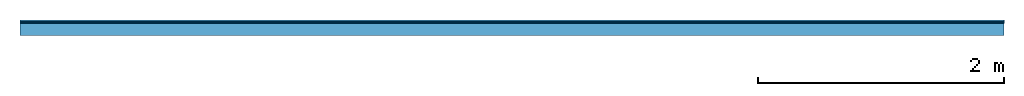
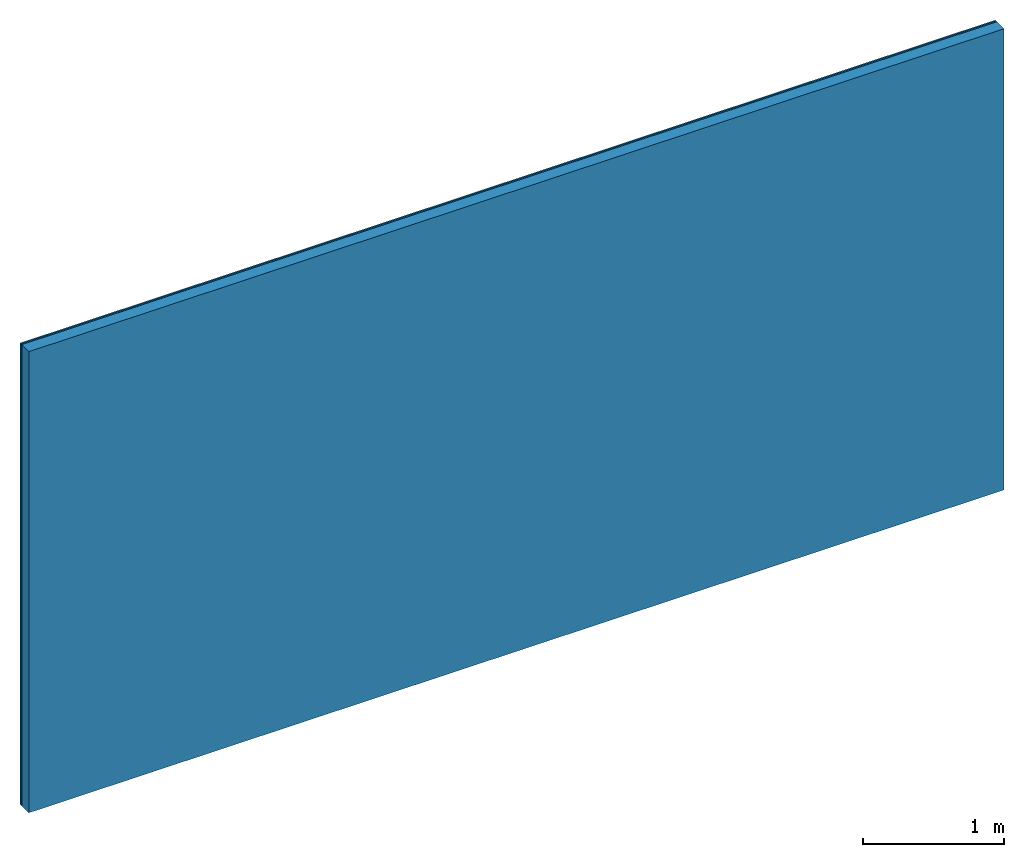
# One storey: 2 plates, 1 member, 1 element without a shape of its own.
"""IFC4 building model written with IfcOpenShell, lengths in metres."""

from ifc_helpers import new_model, si_unit, derived_unit, direction, frame, frame_2d, origin, origin_with_axes, place, context, project, spatial, rectangle, extrude, material, layer, layer_set, type_object, element, aggregate, save


model = new_model("IFC4")

# Units and contexts
plan_context = context("Plan", 3, precision=1e-05, world=origin(), true_north=direction((0.0, 1.0)))
model_context = context("Model", 3, precision=1e-05, world=origin(), true_north=direction((0.0, 1.0)))
ifc_project = project(units=[si_unit("LENGTHUNIT", "METRE"), derived_unit("SOUNDPRESSUREUNIT", [(si_unit("PRESSUREUNIT", "PASCAL", prefix="MICRO"), 0)]), si_unit("ENERGYUNIT", "JOULE", prefix="MEGA"), si_unit("MASSUNIT", "GRAM", prefix="KILO"), derived_unit("THERMALTRANSMITTANCEUNIT", [(si_unit("POWERUNIT", "WATT"), 1), (si_unit("AREAUNIT", "SQUARE_METRE"), -1), (si_unit("THERMODYNAMICTEMPERATUREUNIT", "KELVIN"), -1)]), derived_unit("AREADENSITYUNIT", [(si_unit("MASSUNIT", "GRAM", prefix="KILO"), 1), (si_unit("AREAUNIT", "SQUARE_METRE"), -1)]), derived_unit("USERDEFINED", [(si_unit("ENERGYUNIT", "JOULE", prefix="MEGA"), 1), (si_unit("AREAUNIT", "SQUARE_METRE"), -1)])], contexts=[plan_context, model_context])

# Site, building, storey
site = spatial("IfcSite", under=ifc_project)
building_placement = place(None, origin())
building = spatial("IfcBuilding", under=site, at=building_placement)
storey_placement = place(building_placement, origin())
storey = spatial("IfcBuildingStorey", under=building, at=storey_placement)

# Wall, member, plates
ifc_material_1 = material(Name="joints", Category="04.017")
ifc_layer_1 = layer(ifc_material_1, 0.0, Name="Surface")
ifc_material_2 = material(Name="Rigidur H", Category="03.007")
ifc_layer_2 = layer(ifc_material_2, 0.0125, Name="2nd layer")
ifc_layer_3 = layer(ifc_material_2, 0.0125, Name="1st layer")
ifc_material_3 = material(Name="of the art")
ifc_layer_4 = layer(ifc_material_3, 0.0, Name="Bond")
ifc_layer_5 = layer(None, 0.1, Name="Support")
ifc_layer_set = layer_set([ifc_layer_1, ifc_layer_2, ifc_layer_3, ifc_layer_4, ifc_layer_5])
wall_type = type_object("IfcWallType", Name="C0472", PredefinedType="NOTDEFINED", material=ifc_layer_set)
wall_placement = place(None, frame((0.0, 0.0, 0.0), z_axis=(0.0, -1.0, 0.0), x_axis=(1.0, 0.0, 0.0)))
wall = element("IfcWall", 1, at=wall_placement, inside=storey, type_object=wall_type, material=ifc_layer_set, Name="Wall #1")
ifc_material_4 = material(Name="OSB")
member_placement = place(wall_placement, origin())
member = element("IfcMember", 2, at=member_placement, material=ifc_material_4, Name="Support", context=plan_context, shape_type="SweptSolid", body=[
    extrude(rectangle(XDim=1.0, YDim=0.1, at=frame_2d((0.5, 0.05), x_axis=(1.0, 0.0))), frame((0.0, 4.0, 0.025), z_axis=(0.0, -1.0, 0.0), x_axis=(1.0, 0.0, 0.0)), (0.0, 0.0, 1.0), 4.0),
    extrude(rectangle(XDim=1.0, YDim=0.1, at=frame_2d((0.5, 0.05), x_axis=(1.0, 0.0))), frame((1.0, 4.0, 0.025), z_axis=(0.0, -1.0, 0.0), x_axis=(1.0, 0.0, 0.0)), (0.0, 0.0, 1.0), 4.0),
    extrude(rectangle(XDim=1.0, YDim=0.1, at=frame_2d((0.5, 0.05), x_axis=(1.0, 0.0))), frame((2.0, 4.0, 0.025), z_axis=(0.0, -1.0, 0.0), x_axis=(1.0, 0.0, 0.0)), (0.0, 0.0, 1.0), 4.0),
    extrude(rectangle(XDim=1.0, YDim=0.1, at=frame_2d((0.5, 0.05), x_axis=(1.0, 0.0))), frame((3.0, 4.0, 0.025), z_axis=(0.0, -1.0, 0.0), x_axis=(1.0, 0.0, 0.0)), (0.0, 0.0, 1.0), 4.0),
    extrude(rectangle(XDim=1.0, YDim=0.1, at=frame_2d((0.5, 0.05), x_axis=(1.0, 0.0))), frame((4.0, 4.0, 0.025), z_axis=(0.0, -1.0, 0.0), x_axis=(1.0, 0.0, 0.0)), (0.0, 0.0, 1.0), 4.0),
    extrude(rectangle(XDim=1.0, YDim=0.1, at=frame_2d((0.5, 0.05), x_axis=(1.0, 0.0))), frame((5.0, 4.0, 0.025), z_axis=(0.0, -1.0, 0.0), x_axis=(1.0, 0.0, 0.0)), (0.0, 0.0, 1.0), 4.0),
    extrude(rectangle(XDim=1.0, YDim=0.1, at=frame_2d((0.5, 0.05), x_axis=(1.0, 0.0))), frame((6.0, 4.0, 0.025), z_axis=(0.0, -1.0, 0.0), x_axis=(1.0, 0.0, 0.0)), (0.0, 0.0, 1.0), 4.0),
    extrude(rectangle(XDim=1.0, YDim=0.1, at=frame_2d((0.5, 0.05), x_axis=(1.0, 0.0))), frame((7.0, 4.0, 0.025), z_axis=(0.0, -1.0, 0.0), x_axis=(1.0, 0.0, 0.0)), (0.0, 0.0, 1.0), 4.0),
])
plate_1_placement = place(wall_placement, origin())
plate_1 = element("IfcPlate", 3, at=plate_1_placement, material=ifc_material_2, Name="2nd layer", context=plan_context, shape_type="SweptSolid", body=[
    extrude(rectangle(XDim=8.0, YDim=4.0, at=frame_2d((4.0, 2.0), x_axis=(1.0, 0.0))), origin_with_axes(), (0.0, 0.0, 1.0), 0.0125),
])
plate_2_placement = place(wall_placement, origin())
plate_2 = element("IfcPlate", 4, at=plate_2_placement, material=ifc_material_2, Name="1st layer", context=plan_context, shape_type="SweptSolid", body=[
    extrude(rectangle(XDim=8.0, YDim=4.0, at=frame_2d((4.0, 2.0), x_axis=(1.0, 0.0))), frame((0.0, 0.0, 0.0125), z_axis=(0.0, 0.0, 1.0), x_axis=(1.0, 0.0, 0.0)), (0.0, 0.0, 1.0), 0.0125),
])
aggregate(wall, [plate_1, plate_2, member])

save(model, "model.ifc")
